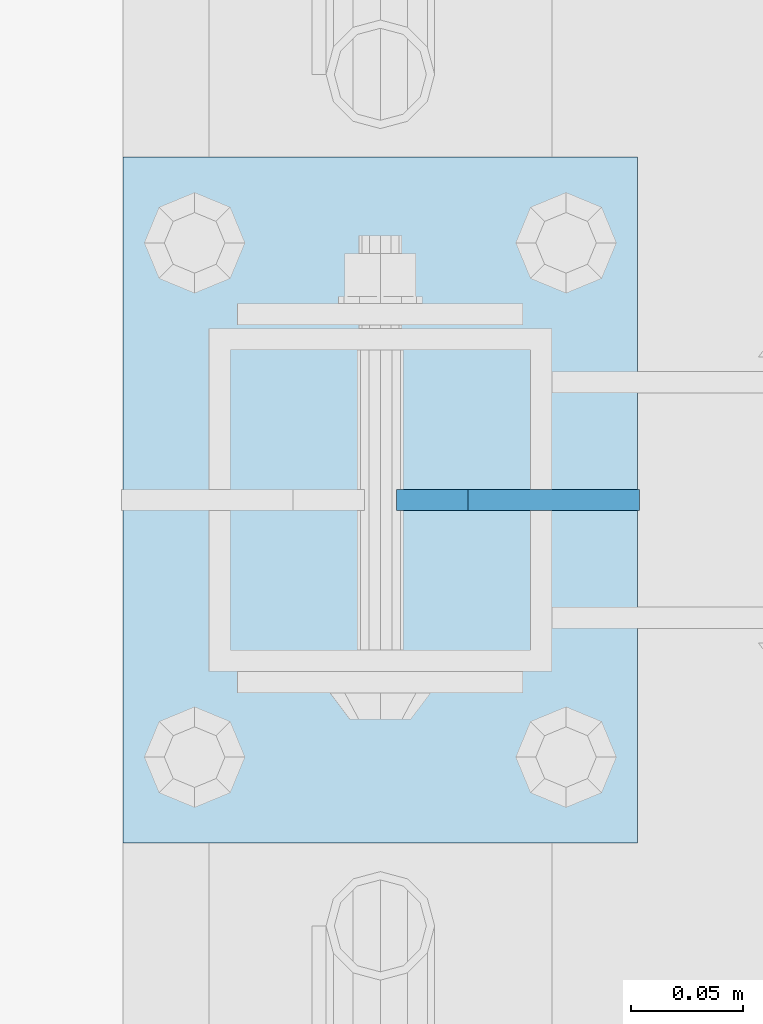
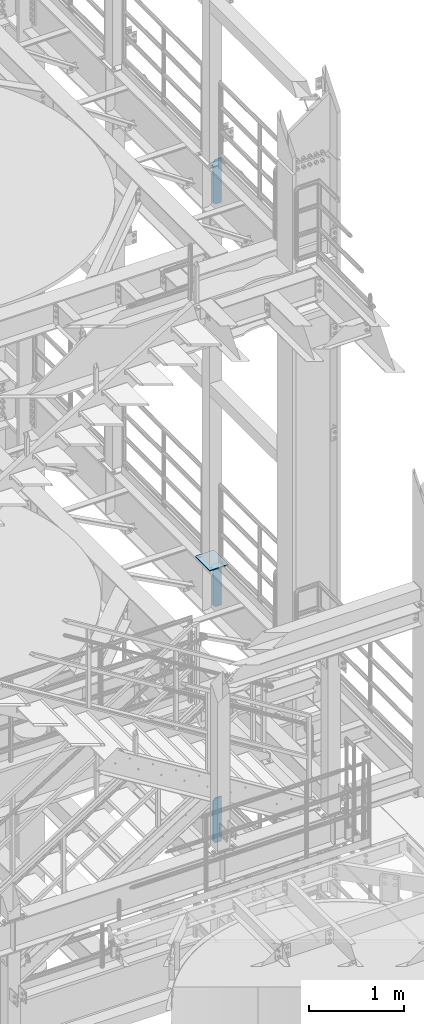
# One storey, part 1529 of 1876: 4 plates, 4 elements without a shape of their own.
"""IFC2X3 building model written with IfcOpenShell, lengths in millimetres."""

from ifc_helpers import new_model, si_unit, frame, origin_with_axes, place, context, subcontext, project, spatial, faceted_brep, material, type_object, element, aggregate, save


model = new_model("IFC2X3")

# Units and contexts
model_context = context("Model", 3, precision=1e-05, world=origin_with_axes())
body_context = subcontext(model_context, "Body", "Model", "MODEL_VIEW")
ifc_project = project(units=[si_unit("LENGTHUNIT", "METRE", prefix="MILLI"), si_unit("AREAUNIT", "SQUARE_METRE"), si_unit("VOLUMEUNIT", "CUBIC_METRE"), si_unit("MASSUNIT", "GRAM", prefix="KILO"), si_unit("TIMEUNIT", "SECOND"), si_unit("PLANEANGLEUNIT", "RADIAN"), si_unit("SOLIDANGLEUNIT", "STERADIAN"), si_unit("THERMODYNAMICTEMPERATUREUNIT", "DEGREE_CELSIUS"), si_unit("LUMINOUSINTENSITYUNIT", "LUMEN")], contexts=[model_context])

# Site, building, storey
site_placement = place(None, origin_with_axes())
site = spatial("IfcSite", under=ifc_project, at=site_placement, CompositionType="ELEMENT")
building_placement = place(site_placement, origin_with_axes())
building = spatial("IfcBuilding", under=site, at=building_placement, Name="Undefined", CompositionType="ELEMENT")
storey_placement = place(building_placement, origin_with_axes())
storey = spatial("IfcBuildingStorey", under=building, at=storey_placement, Name="Undefined", CompositionType="ELEMENT", Elevation=0.0)

# Assembly, plate
assembly_1_placement = place(storey_placement, origin_with_axes())
assembly_1 = element("IfcElementAssembly", 1, at=assembly_1_placement, inside=storey, Name="BEAM", AssemblyPlace="NOTDEFINED", PredefinedType="RIGID_FRAME")
ifc_material = material(Name="STEEL/A36")
plate_type_1 = type_object("IfcPlateType", PredefinedType="NOTDEFINED")
plate_1_placement = place(assembly_1_placement, frame((7735.0937513462, -2540.00000037862, 12712.7), z_axis=(0.0, 0.0, 1.0), x_axis=(-1.0, 0.0, 0.0)))
plate_1 = element("IfcPlate", 2, at=plate_1_placement, type_object=plate_type_1, material=ifc_material, Name="PLATE", context=body_context, shape_type="Brep", body=[
    faceted_brep([(0.0, -4.76249999999982, 0.0), (0.0, -4.76249999999982, 571.5), (0.0, 4.76249999999982, 571.5), (0.0, 4.76249999999982, 0.0), (76.1999969482422, -4.76249999999982, 571.5), (76.1999969482422, 4.76249999999982, 571.5), (107.949996948242, -4.76249999999982, 539.75), (107.949996948242, 4.76249999999982, 539.75), (107.949996948242, -4.76249999999982, 31.75), (107.949996948242, 4.76249999999982, 31.75), (76.1999969482422, -4.76250000000073, 0.0), (76.1999969482422, 4.76250000000073, 0.0)], [[[0, 1, 2, 3]], [[1, 4, 5, 2]], [[4, 6, 7, 5]], [[6, 8, 9, 7]], [[8, 10, 11, 9]], [[10, 0, 3, 11]], [[5, 7, 9, 11, 3, 2]], [[10, 8, 6, 4, 1, 0]]]),
])
aggregate(assembly_1, [plate_1])

assembly_2_placement = place(storey_placement, origin_with_axes())
assembly_2 = element("IfcElementAssembly", 3, at=assembly_2_placement, inside=storey, Name="BEAM", AssemblyPlace="NOTDEFINED", PredefinedType="RIGID_FRAME")
plate_2_placement = place(assembly_2_placement, frame((7735.09375, -2540.0, 7556.5), z_axis=(0.0, 0.0, 1.0), x_axis=(-1.0, 0.0, 0.0)))
plate_2 = element("IfcPlate", 4, at=plate_2_placement, type_object=plate_type_1, material=ifc_material, Name="PLATE", context=body_context, shape_type="Brep", body=[
    faceted_brep([(0.0, -4.76249999999982, 0.0), (0.0, -4.76249999999982, 571.5), (0.0, 4.76249999999982, 571.5), (0.0, 4.76249999999982, 0.0), (76.1999969482422, -4.76249999999982, 571.5), (76.1999969482422, 4.76249999999982, 571.5), (107.949996948242, -4.76249999999982, 539.75), (107.949996948242, 4.76249999999982, 539.75), (107.949996948242, -4.76249999999982, 31.75), (107.949996948242, 4.76249999999982, 31.75), (76.1999969482422, -4.76250000000073, 0.0), (76.1999969482422, 4.76250000000073, 0.0)], [[[0, 1, 2, 3]], [[1, 4, 5, 2]], [[4, 6, 7, 5]], [[6, 8, 9, 7]], [[8, 10, 11, 9]], [[10, 0, 3, 11]], [[5, 7, 9, 11, 3, 2]], [[10, 8, 6, 4, 1, 0]]]),
])
aggregate(assembly_2, [plate_2])

assembly_3_placement = place(storey_placement, origin_with_axes())
assembly_3 = element("IfcElementAssembly", 5, at=assembly_3_placement, inside=storey, Name="BEAM", AssemblyPlace="NOTDEFINED", PredefinedType="RIGID_FRAME")
plate_3_placement = place(assembly_3_placement, frame((7735.09375, -2540.0, 4533.9), z_axis=(0.0, 0.0, 1.0), x_axis=(-1.0, 0.0, 0.0)))
plate_3 = element("IfcPlate", 6, at=plate_3_placement, type_object=plate_type_1, material=ifc_material, Name="PLATE", context=body_context, shape_type="Brep", body=[
    faceted_brep([(0.0, -4.76249999999982, 0.0), (0.0, -4.76249999999982, 571.5), (0.0, 4.76249999999982, 571.5), (0.0, 4.76249999999982, 0.0), (76.1999969482422, -4.76249999999982, 571.5), (76.1999969482422, 4.76249999999982, 571.5), (107.949996948242, -4.76249999999982, 539.75), (107.949996948242, 4.76249999999982, 539.75), (107.949996948242, -4.76249999999982, 31.75), (107.949996948242, 4.76249999999982, 31.75), (76.1999969482422, -4.76250000000073, 0.0), (76.1999969482422, 4.76250000000073, 0.0)], [[[0, 1, 2, 3]], [[1, 4, 5, 2]], [[4, 6, 7, 5]], [[6, 8, 9, 7]], [[8, 10, 11, 9]], [[10, 0, 3, 11]], [[5, 7, 9, 11, 3, 2]], [[10, 8, 6, 4, 1, 0]]]),
])
aggregate(assembly_3, [plate_3])

assembly_4_placement = place(storey_placement, origin_with_axes())
assembly_4 = element("IfcElementAssembly", 7, at=assembly_4_placement, inside=storey, Name="BEAM", AssemblyPlace="NOTDEFINED", PredefinedType="RIGID_FRAME")
plate_type_2 = type_object("IfcPlateType", PredefinedType="NOTDEFINED")
plate_4_placement = place(assembly_4_placement, frame((7505.7, -2692.4, 8159.75), z_axis=(0.0, 1.0, 0.0), x_axis=(1.0, 0.0, 0.0)))
plate_4 = element("IfcPlate", 8, at=plate_4_placement, type_object=plate_type_2, material=ifc_material, Name="PLATE", context=body_context, shape_type="Brep", body=[
    faceted_brep([(0.0, -6.35000000000036, 0.0), (0.0, -6.35000000000036, 304.799987792969), (0.0, 6.35000000000036, 304.799987792969), (0.0, 6.35000000000036, 0.0), (228.600006103516, -6.34999999999854, 304.799987792969), (228.600006103516, 6.34999999999854, 304.799987792969), (228.600006103516, -6.34999999999854, 0.0), (228.600006103516, 6.34999999999854, 0.0)], [[[0, 1, 2, 3]], [[1, 4, 5, 2]], [[4, 6, 7, 5]], [[6, 0, 3, 7]], [[5, 7, 3, 2]], [[6, 4, 1, 0]]]),
])
aggregate(assembly_4, [plate_4])

save(model, "model.ifc")
